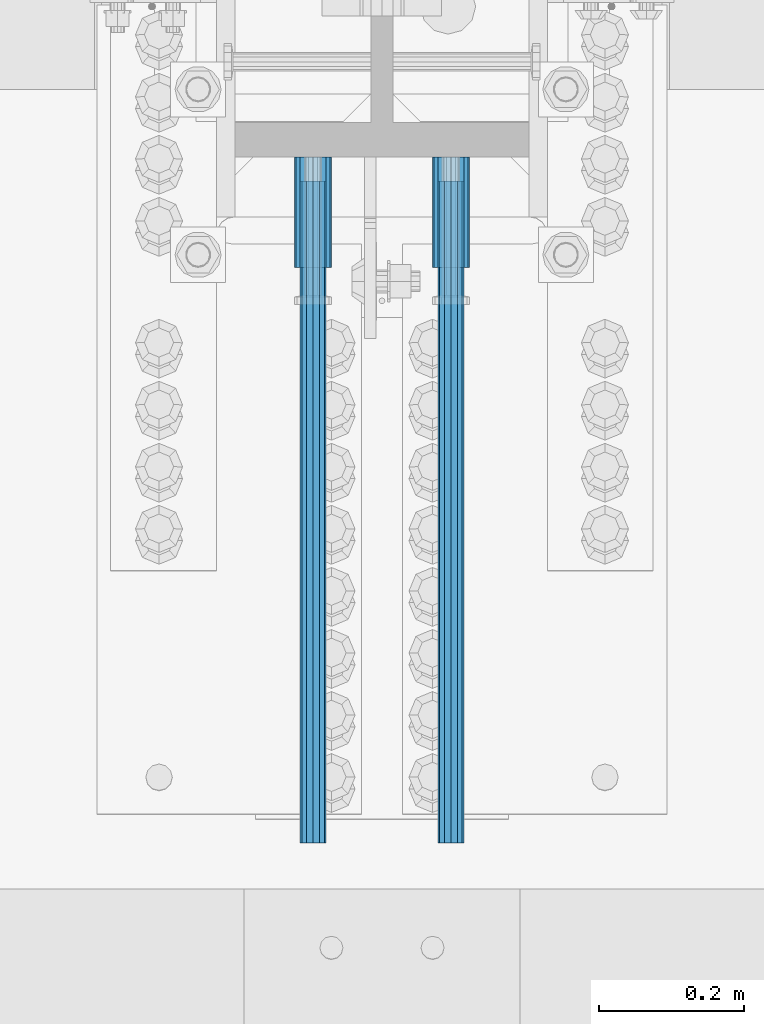
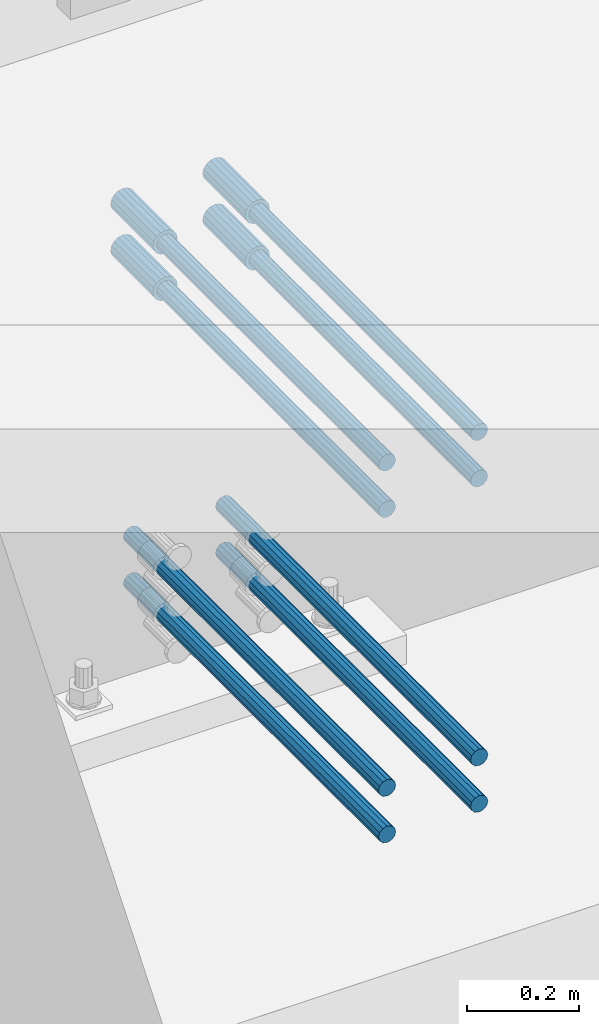
# One storey, part 1314 of 1763: 12 beams, 9 elements without a shape of their own.
"""IFC2X3 building model written with IfcOpenShell, lengths in millimetres."""

from ifc_helpers import new_model, si_unit, frame, origin_with_axes, place, context, subcontext, project, spatial, faceted_brep, material, type_object, element, aggregate, save


model = new_model("IFC2X3")

# Units and contexts
model_context = context("Model", 3, precision=1e-05, world=origin_with_axes())
body_context = subcontext(model_context, "Body", "Model", "MODEL_VIEW")
ifc_project = project(units=[si_unit("LENGTHUNIT", "METRE", prefix="MILLI"), si_unit("AREAUNIT", "SQUARE_METRE"), si_unit("VOLUMEUNIT", "CUBIC_METRE"), si_unit("MASSUNIT", "GRAM", prefix="KILO"), si_unit("TIMEUNIT", "SECOND"), si_unit("PLANEANGLEUNIT", "RADIAN"), si_unit("SOLIDANGLEUNIT", "STERADIAN"), si_unit("THERMODYNAMICTEMPERATUREUNIT", "DEGREE_CELSIUS"), si_unit("LUMINOUSINTENSITYUNIT", "LUMEN")], contexts=[model_context])

# Site, building, storey
site_placement = place(None, origin_with_axes())
site = spatial("IfcSite", under=ifc_project, at=site_placement, CompositionType="ELEMENT")
building_placement = place(site_placement, origin_with_axes())
building = spatial("IfcBuilding", under=site, at=building_placement, Name="Undefined", CompositionType="ELEMENT")
storey_placement = place(building_placement, origin_with_axes())
storey = spatial("IfcBuildingStorey", under=building, at=storey_placement, Name="Undefined", CompositionType="ELEMENT", Elevation=0.0)

# Assembly, beams
assembly_1_placement = place(storey_placement, origin_with_axes())
assembly_1 = element("IfcElementAssembly", 1, at=assembly_1_placement, inside=storey, Name="COLUMN", AssemblyPlace="NOTDEFINED", PredefinedType="RIGID_FRAME")
ifc_material = material(Name="STEEL/A706-GR.80")
beam_type_1 = type_object("IfcBeamType", PredefinedType="NOTDEFINED")
beam_1_placement = place(assembly_1_placement, frame((-24123.0872736984, 13482.6375920513, 4775.20000000009), z_axis=(0.0, 0.0, 1.0), x_axis=(0.0, -1.0, 0.0)))
beam_1 = element("IfcBeam", 2, at=beam_1_placement, type_object=beam_type_1, material=ifc_material, Name="HALF COUPLER F", context=body_context, shape_type="Brep", body=[
    faceted_brep([(32.7659999999996, -8.95349999999962, -15.507916905568), (32.7659999999996, 0.0, -17.9070000000002), (32.7659999999996, 8.95349999999962, -15.507916905568), (32.7659999999996, 15.507916905568, -8.95350000000008), (32.7659999999996, 17.9069999999992, 0.0), (32.7659999999996, 15.507916905568, 8.95350000000008), (32.7659999999996, 8.95349999999962, 15.507916905568), (32.7659999999996, 0.0, 17.9070000000002), (32.7659999999996, -8.95349999999962, 15.507916905568), (32.7659999999996, -15.507916905568, 8.95350000000008), (32.7659999999996, -17.9069999999992, 0.0), (32.7659999999996, -15.507916905568, -8.95350000000008), (152.400103102711, -15.507916905568, 8.95350000000008), (152.400103102711, -8.95349999999962, 15.507916905568), (152.400103102711, -17.9069999999992, 0.0), (152.400103102711, -15.507916905568, -8.95350000000008), (152.400103102711, -8.95349999999962, -15.507916905568), (152.400103102711, 0.0, -17.9070000000002), (152.400103102711, 8.95349999999962, -15.507916905568), (152.400103102711, 15.507916905568, -8.95350000000008), (152.400103102711, 17.9069999999992, 0.0), (152.400103102711, 15.507916905568, 8.95350000000008), (152.400103102711, 8.95349999999962, 15.507916905568), (152.400103102711, 0.0, 17.9070000000002), (0.0, -23.466540125788, 9.72015918207308), (0.0, -17.9605122421381, 17.9605122421385), (0.0, -9.72015918207398, 23.4665401257867), (0.0, 0.0, 25.4000000000001), (0.0, 9.72015918207398, 23.4665401257867), (0.0, 17.9605122421381, 17.9605122421385), (0.0, 23.466540125788, 9.72015918207308), (0.0, 25.4000000000015, 0.0), (0.0, 23.466540125788, -9.72015918207308), (0.0, 17.9605122421381, -17.9605122421385), (0.0, 9.72015918207398, -23.4665401257867), (0.0, 0.0, -25.4000000000001), (0.0, -9.72015918207398, -23.4665401257867), (0.0, -17.9605122421381, -17.9605122421385), (0.0, -23.466540125788, -9.72015918207308), (0.0, -25.4000000000015, 0.0), (152.400103102711, -25.4000000000015, 0.0), (152.400103102711, -23.466540125788, 9.72015918207308), (152.400103102711, -17.9605122421381, 17.9605122421385), (152.400103102711, -9.72015918207398, 23.4665401257867), (152.400103102711, 0.0, 25.4000000000001), (152.400103102711, 9.72015918207398, 23.4665401257867), (152.400103102711, 17.9605122421381, 17.9605122421385), (152.400103102711, 23.466540125788, 9.72015918207308), (152.400103102711, 25.4000000000015, 0.0), (152.400103102711, 23.466540125788, -9.72015918207308), (152.400103102711, 17.9605122421381, -17.9605122421385), (152.400103102711, 9.72015918207398, -23.4665401257867), (152.400103102711, 0.0, -25.4000000000001), (152.400103102711, -9.72015918207398, -23.4665401257867), (152.400103102711, -17.9605122421381, -17.9605122421385), (152.400103102711, -23.466540125788, -9.72015918207308)], [[[0, 1, 2, 3, 4, 5, 6, 7, 8, 9, 10, 11]], [[12, 9, 8, 13]], [[14, 10, 9, 12]], [[15, 11, 10, 14]], [[16, 0, 11, 15]], [[17, 1, 0, 16]], [[18, 2, 1, 17]], [[19, 3, 2, 18]], [[20, 4, 3, 19]], [[21, 5, 4, 20]], [[22, 6, 5, 21]], [[23, 7, 6, 22]], [[13, 8, 7, 23]], [[24, 25, 26, 27, 28, 29, 30, 31, 32, 33, 34, 35, 36, 37, 38, 39]], [[24, 39, 40, 41]], [[25, 24, 41, 42]], [[26, 25, 42, 43]], [[27, 26, 43, 44]], [[28, 27, 44, 45]], [[29, 28, 45, 46]], [[30, 29, 46, 47]], [[31, 30, 47, 48]], [[32, 31, 48, 49]], [[33, 32, 49, 50]], [[34, 33, 50, 51]], [[35, 34, 51, 52]], [[36, 35, 52, 53]], [[37, 36, 53, 54]], [[38, 37, 54, 55]], [[39, 38, 55, 40]], [[54, 53, 52, 51, 50, 49, 48, 47, 46, 45, 44, 43, 42, 41, 40, 55], [21, 20, 19, 18, 17, 16, 15, 14, 12, 13, 23, 22]]]),
])
beam_2_placement = place(assembly_1_placement, frame((-23932.5872736985, 13482.6376607869, 4775.20000000009), z_axis=(0.0, 0.0, 1.0), x_axis=(0.0, -1.0, 0.0)))
beam_2 = element("IfcBeam", 3, at=beam_2_placement, type_object=beam_type_1, material=ifc_material, Name="HALF COUPLER F", context=body_context, shape_type="Brep", body=[
    faceted_brep([(32.7659999999996, -8.95349999999962, -15.507916905568), (32.7659999999996, 0.0, -17.9070000000002), (32.7659999999996, 8.95349999999962, -15.507916905568), (32.7659999999996, 15.507916905568, -8.95350000000008), (32.7659999999996, 17.9069999999992, 0.0), (32.7659999999996, 15.507916905568, 8.95350000000008), (32.7659999999996, 8.95349999999962, 15.507916905568), (32.7659999999996, 0.0, 17.9070000000002), (32.7659999999996, -8.95349999999962, 15.507916905568), (32.7659999999996, -15.507916905568, 8.95350000000008), (32.7659999999996, -17.9069999999992, 0.0), (32.7659999999996, -15.507916905568, -8.95350000000008), (152.400103102711, -15.507916905568, 8.95350000000008), (152.400103102711, -8.95349999999962, 15.507916905568), (152.400103102711, -17.9069999999992, 0.0), (152.400103102711, -15.507916905568, -8.95350000000008), (152.400103102711, -8.95349999999962, -15.507916905568), (152.400103102711, 0.0, -17.9070000000002), (152.400103102711, 8.95349999999962, -15.507916905568), (152.400103102711, 15.507916905568, -8.95350000000008), (152.400103102711, 17.9069999999992, 0.0), (152.400103102711, 15.507916905568, 8.95350000000008), (152.400103102711, 8.95349999999962, 15.507916905568), (152.400103102711, 0.0, 17.9070000000002), (0.0, -23.466540125788, 9.72015918207308), (0.0, -17.9605122421381, 17.9605122421385), (0.0, -9.72015918207398, 23.4665401257867), (0.0, 0.0, 25.4000000000001), (0.0, 9.72015918207398, 23.4665401257867), (0.0, 17.9605122421381, 17.9605122421385), (0.0, 23.466540125788, 9.72015918207308), (0.0, 25.4000000000015, 0.0), (0.0, 23.466540125788, -9.72015918207308), (0.0, 17.9605122421381, -17.9605122421385), (0.0, 9.72015918207398, -23.4665401257867), (0.0, 0.0, -25.4000000000001), (0.0, -9.72015918207398, -23.4665401257867), (0.0, -17.9605122421381, -17.9605122421385), (0.0, -23.466540125788, -9.72015918207308), (0.0, -25.4000000000015, 0.0), (152.400103102711, -25.4000000000015, 0.0), (152.400103102711, -23.466540125788, 9.72015918207308), (152.400103102711, -17.9605122421381, 17.9605122421385), (152.400103102711, -9.72015918207398, 23.4665401257867), (152.400103102711, 0.0, 25.4000000000001), (152.400103102711, 9.72015918207398, 23.4665401257867), (152.400103102711, 17.9605122421381, 17.9605122421385), (152.400103102711, 23.466540125788, 9.72015918207308), (152.400103102711, 25.4000000000015, 0.0), (152.400103102711, 23.466540125788, -9.72015918207308), (152.400103102711, 17.9605122421381, -17.9605122421385), (152.400103102711, 9.72015918207398, -23.4665401257867), (152.400103102711, 0.0, -25.4000000000001), (152.400103102711, -9.72015918207398, -23.4665401257867), (152.400103102711, -17.9605122421381, -17.9605122421385), (152.400103102711, -23.466540125788, -9.72015918207308)], [[[0, 1, 2, 3, 4, 5, 6, 7, 8, 9, 10, 11]], [[12, 9, 8, 13]], [[14, 10, 9, 12]], [[15, 11, 10, 14]], [[16, 0, 11, 15]], [[17, 1, 0, 16]], [[18, 2, 1, 17]], [[19, 3, 2, 18]], [[20, 4, 3, 19]], [[21, 5, 4, 20]], [[22, 6, 5, 21]], [[23, 7, 6, 22]], [[13, 8, 7, 23]], [[24, 25, 26, 27, 28, 29, 30, 31, 32, 33, 34, 35, 36, 37, 38, 39]], [[24, 39, 40, 41]], [[25, 24, 41, 42]], [[26, 25, 42, 43]], [[27, 26, 43, 44]], [[28, 27, 44, 45]], [[29, 28, 45, 46]], [[30, 29, 46, 47]], [[31, 30, 47, 48]], [[32, 31, 48, 49]], [[33, 32, 49, 50]], [[34, 33, 50, 51]], [[35, 34, 51, 52]], [[36, 35, 52, 53]], [[37, 36, 53, 54]], [[38, 37, 54, 55]], [[39, 38, 55, 40]], [[54, 53, 52, 51, 50, 49, 48, 47, 46, 45, 44, 43, 42, 41, 40, 55], [21, 20, 19, 18, 17, 16, 15, 14, 12, 13, 23, 22]]]),
])
beam_3_placement = place(assembly_1_placement, frame((-24123.0872736984, 13482.6374545803, 4876.80000000009), z_axis=(0.0, 0.0, 1.0), x_axis=(0.0, -1.0, 0.0)))
beam_3 = element("IfcBeam", 4, at=beam_3_placement, type_object=beam_type_1, material=ifc_material, Name="HALF COUPLER F", context=body_context, shape_type="Brep", body=[
    faceted_brep([(32.7659999999996, -8.95349999999962, -15.507916905568), (32.7659999999996, 0.0, -17.9070000000002), (32.7659999999996, 8.95349999999962, -15.507916905568), (32.7659999999996, 15.507916905568, -8.95350000000008), (32.7659999999996, 17.9069999999992, 0.0), (32.7659999999996, 15.507916905568, 8.95350000000008), (32.7659999999996, 8.95349999999962, 15.507916905568), (32.7659999999996, 0.0, 17.9070000000002), (32.7659999999996, -8.95349999999962, 15.507916905568), (32.7659999999996, -15.507916905568, 8.95350000000008), (32.7659999999996, -17.9069999999992, 0.0), (32.7659999999996, -15.507916905568, -8.95350000000008), (152.400103102711, -15.507916905568, 8.95350000000008), (152.400103102711, -8.95349999999962, 15.507916905568), (152.400103102711, -17.9069999999992, 0.0), (152.400103102711, -15.507916905568, -8.95350000000008), (152.400103102711, -8.95349999999962, -15.507916905568), (152.400103102711, 0.0, -17.9070000000002), (152.400103102711, 8.95349999999962, -15.507916905568), (152.400103102711, 15.507916905568, -8.95350000000008), (152.400103102711, 17.9069999999992, 0.0), (152.400103102711, 15.507916905568, 8.95350000000008), (152.400103102711, 8.95349999999962, 15.507916905568), (152.400103102711, 0.0, 17.9070000000002), (0.0, -23.466540125788, 9.72015918207308), (0.0, -17.9605122421381, 17.9605122421385), (0.0, -9.72015918207398, 23.4665401257867), (0.0, 0.0, 25.4000000000001), (0.0, 9.72015918207398, 23.4665401257867), (0.0, 17.9605122421381, 17.9605122421385), (0.0, 23.466540125788, 9.72015918207308), (0.0, 25.4000000000015, 0.0), (0.0, 23.466540125788, -9.72015918207308), (0.0, 17.9605122421381, -17.9605122421385), (0.0, 9.72015918207398, -23.4665401257867), (0.0, 0.0, -25.4000000000001), (0.0, -9.72015918207398, -23.4665401257867), (0.0, -17.9605122421381, -17.9605122421385), (0.0, -23.466540125788, -9.72015918207308), (0.0, -25.4000000000015, 0.0), (152.400103102711, -25.4000000000015, 0.0), (152.400103102711, -23.466540125788, 9.72015918207308), (152.400103102711, -17.9605122421381, 17.9605122421385), (152.400103102711, -9.72015918207398, 23.4665401257867), (152.400103102711, 0.0, 25.4000000000001), (152.400103102711, 9.72015918207398, 23.4665401257867), (152.400103102711, 17.9605122421381, 17.9605122421385), (152.400103102711, 23.466540125788, 9.72015918207308), (152.400103102711, 25.4000000000015, 0.0), (152.400103102711, 23.466540125788, -9.72015918207308), (152.400103102711, 17.9605122421381, -17.9605122421385), (152.400103102711, 9.72015918207398, -23.4665401257867), (152.400103102711, 0.0, -25.4000000000001), (152.400103102711, -9.72015918207398, -23.4665401257867), (152.400103102711, -17.9605122421381, -17.9605122421385), (152.400103102711, -23.466540125788, -9.72015918207308)], [[[0, 1, 2, 3, 4, 5, 6, 7, 8, 9, 10, 11]], [[12, 9, 8, 13]], [[14, 10, 9, 12]], [[15, 11, 10, 14]], [[16, 0, 11, 15]], [[17, 1, 0, 16]], [[18, 2, 1, 17]], [[19, 3, 2, 18]], [[20, 4, 3, 19]], [[21, 5, 4, 20]], [[22, 6, 5, 21]], [[23, 7, 6, 22]], [[13, 8, 7, 23]], [[24, 25, 26, 27, 28, 29, 30, 31, 32, 33, 34, 35, 36, 37, 38, 39]], [[24, 39, 40, 41]], [[25, 24, 41, 42]], [[26, 25, 42, 43]], [[27, 26, 43, 44]], [[28, 27, 44, 45]], [[29, 28, 45, 46]], [[30, 29, 46, 47]], [[31, 30, 47, 48]], [[32, 31, 48, 49]], [[33, 32, 49, 50]], [[34, 33, 50, 51]], [[35, 34, 51, 52]], [[36, 35, 52, 53]], [[37, 36, 53, 54]], [[38, 37, 54, 55]], [[39, 38, 55, 40]], [[54, 53, 52, 51, 50, 49, 48, 47, 46, 45, 44, 43, 42, 41, 40, 55], [21, 20, 19, 18, 17, 16, 15, 14, 12, 13, 23, 22]]]),
])
beam_4_placement = place(assembly_1_placement, frame((-23932.5872736985, 13482.6375233158, 4876.80000000009), z_axis=(0.0, 0.0, 1.0), x_axis=(0.0, -1.0, 0.0)))
beam_4 = element("IfcBeam", 5, at=beam_4_placement, type_object=beam_type_1, material=ifc_material, Name="HALF COUPLER F", context=body_context, shape_type="Brep", body=[
    faceted_brep([(32.7659999999996, -8.95349999999962, -15.507916905568), (32.7659999999996, 0.0, -17.9070000000002), (32.7659999999996, 8.95349999999962, -15.507916905568), (32.7659999999996, 15.507916905568, -8.95350000000008), (32.7659999999996, 17.9069999999992, 0.0), (32.7659999999996, 15.507916905568, 8.95350000000008), (32.7659999999996, 8.95349999999962, 15.507916905568), (32.7659999999996, 0.0, 17.9070000000002), (32.7659999999996, -8.95349999999962, 15.507916905568), (32.7659999999996, -15.507916905568, 8.95350000000008), (32.7659999999996, -17.9069999999992, 0.0), (32.7659999999996, -15.507916905568, -8.95350000000008), (152.400103102711, -15.507916905568, 8.95350000000008), (152.400103102711, -8.95349999999962, 15.507916905568), (152.400103102711, -17.9069999999992, 0.0), (152.400103102711, -15.507916905568, -8.95350000000008), (152.400103102711, -8.95349999999962, -15.507916905568), (152.400103102711, 0.0, -17.9070000000002), (152.400103102711, 8.95349999999962, -15.507916905568), (152.400103102711, 15.507916905568, -8.95350000000008), (152.400103102711, 17.9069999999992, 0.0), (152.400103102711, 15.507916905568, 8.95350000000008), (152.400103102711, 8.95349999999962, 15.507916905568), (152.400103102711, 0.0, 17.9070000000002), (0.0, -23.466540125788, 9.72015918207308), (0.0, -17.9605122421381, 17.9605122421385), (0.0, -9.72015918207398, 23.4665401257867), (0.0, 0.0, 25.4000000000001), (0.0, 9.72015918207398, 23.4665401257867), (0.0, 17.9605122421381, 17.9605122421385), (0.0, 23.466540125788, 9.72015918207308), (0.0, 25.4000000000015, 0.0), (0.0, 23.466540125788, -9.72015918207308), (0.0, 17.9605122421381, -17.9605122421385), (0.0, 9.72015918207398, -23.4665401257867), (0.0, 0.0, -25.4000000000001), (0.0, -9.72015918207398, -23.4665401257867), (0.0, -17.9605122421381, -17.9605122421385), (0.0, -23.466540125788, -9.72015918207308), (0.0, -25.4000000000015, 0.0), (152.400103102711, -25.4000000000015, 0.0), (152.400103102711, -23.466540125788, 9.72015918207308), (152.400103102711, -17.9605122421381, 17.9605122421385), (152.400103102711, -9.72015918207398, 23.4665401257867), (152.400103102711, 0.0, 25.4000000000001), (152.400103102711, 9.72015918207398, 23.4665401257867), (152.400103102711, 17.9605122421381, 17.9605122421385), (152.400103102711, 23.466540125788, 9.72015918207308), (152.400103102711, 25.4000000000015, 0.0), (152.400103102711, 23.466540125788, -9.72015918207308), (152.400103102711, 17.9605122421381, -17.9605122421385), (152.400103102711, 9.72015918207398, -23.4665401257867), (152.400103102711, 0.0, -25.4000000000001), (152.400103102711, -9.72015918207398, -23.4665401257867), (152.400103102711, -17.9605122421381, -17.9605122421385), (152.400103102711, -23.466540125788, -9.72015918207308)], [[[0, 1, 2, 3, 4, 5, 6, 7, 8, 9, 10, 11]], [[12, 9, 8, 13]], [[14, 10, 9, 12]], [[15, 11, 10, 14]], [[16, 0, 11, 15]], [[17, 1, 0, 16]], [[18, 2, 1, 17]], [[19, 3, 2, 18]], [[20, 4, 3, 19]], [[21, 5, 4, 20]], [[22, 6, 5, 21]], [[23, 7, 6, 22]], [[13, 8, 7, 23]], [[24, 25, 26, 27, 28, 29, 30, 31, 32, 33, 34, 35, 36, 37, 38, 39]], [[24, 39, 40, 41]], [[25, 24, 41, 42]], [[26, 25, 42, 43]], [[27, 26, 43, 44]], [[28, 27, 44, 45]], [[29, 28, 45, 46]], [[30, 29, 46, 47]], [[31, 30, 47, 48]], [[32, 31, 48, 49]], [[33, 32, 49, 50]], [[34, 33, 50, 51]], [[35, 34, 51, 52]], [[36, 35, 52, 53]], [[37, 36, 53, 54]], [[38, 37, 54, 55]], [[39, 38, 55, 40]], [[54, 53, 52, 51, 50, 49, 48, 47, 46, 45, 44, 43, 42, 41, 40, 55], [21, 20, 19, 18, 17, 16, 15, 14, 12, 13, 23, 22]]]),
])
aggregate(assembly_1, [beam_1, beam_2, beam_3, beam_4])

# Assembly, beam
assembly_2_placement = place(storey_placement, origin_with_axes())
assembly_2 = element("IfcElementAssembly", 6, at=assembly_2_placement, inside=storey, Name="REBAR", AssemblyPlace="NOTDEFINED", PredefinedType="RIGID_FRAME")
beam_type_2 = type_object("IfcBeamType", Name="#11 REBAR", PredefinedType="NOTDEFINED")
beam_5_placement = place(assembly_2_placement, frame((-24123.0872736978, 13449.8717982573, 4165.6), z_axis=(0.0, 0.0, 1.0), x_axis=(0.0, -1.0, 0.0)))
beam_5 = element("IfcBeam", 7, at=beam_5_placement, type_object=beam_type_2, material=ifc_material, Name="REBAR", ObjectType="#11 REBAR", context=body_context, shape_type="Brep", body=[
    faceted_brep([(0.0, -17.9069999999992, 0.0), (0.0, -15.507916905568, -8.95349999999962), (914.400000001086, -15.507916905568, -8.95349999999962), (914.400000001086, -17.9069999999992, 0.0), (0.0, -8.95349999999962, -15.507916905568), (914.400000001086, -8.95349999999962, -15.507916905568), (0.0, 0.0, -17.9070000000002), (914.400000001086, 0.0, -17.9070000000002), (0.0, 8.95349999999962, -15.507916905568), (914.400000001086, 8.95349999999962, -15.507916905568), (0.0, 15.507916905568, -8.95349999999962), (914.400000001086, 15.507916905568, -8.95349999999962), (0.0, 17.9069999999992, 0.0), (914.400000001086, 17.9069999999992, 0.0), (0.0, 15.507916905568, 8.95349999999962), (914.400000001086, 15.507916905568, 8.95349999999962), (0.0, 8.95349999999962, 15.507916905568), (914.400000001086, 8.95349999999962, 15.507916905568), (0.0, 0.0, 17.9070000000002), (914.400000001086, 0.0, 17.9070000000002), (0.0, -8.95349999999962, 15.507916905568), (914.400000001086, -8.95349999999962, 15.507916905568), (0.0, -15.507916905568, 8.95349999999962), (914.400000001086, -15.507916905568, 8.95349999999962)], [[[0, 1, 2, 3]], [[1, 4, 5, 2]], [[4, 6, 7, 5]], [[6, 8, 9, 7]], [[8, 10, 11, 9]], [[10, 12, 13, 11]], [[12, 14, 15, 13]], [[14, 16, 17, 15]], [[16, 18, 19, 17]], [[18, 20, 21, 19]], [[20, 22, 23, 21]], [[22, 0, 3, 23]], [[5, 7, 9, 11, 13, 15, 17, 19, 21, 23, 3, 2]], [[22, 20, 18, 16, 14, 12, 10, 8, 6, 4, 1, 0]]]),
])
aggregate(assembly_2, [beam_5])

assembly_3_placement = place(storey_placement, origin_with_axes())
assembly_3 = element("IfcElementAssembly", 8, at=assembly_3_placement, inside=storey, Name="REBAR", AssemblyPlace="NOTDEFINED", PredefinedType="RIGID_FRAME")
beam_6_placement = place(assembly_3_placement, frame((-23932.5872736984, 13449.8717295968, 4165.6), z_axis=(0.0, 0.0, 1.0), x_axis=(0.0, -1.0, 0.0)))
beam_6 = element("IfcBeam", 9, at=beam_6_placement, type_object=beam_type_2, material=ifc_material, Name="REBAR", ObjectType="#11 REBAR", context=body_context, shape_type="Brep", body=[
    faceted_brep([(0.0, -17.9069999999992, 0.0), (0.0, -15.507916905568, -8.95349999999962), (914.400000001086, -15.507916905568, -8.95349999999962), (914.400000001086, -17.9069999999992, 0.0), (0.0, -8.95349999999962, -15.507916905568), (914.400000001086, -8.95349999999962, -15.507916905568), (0.0, 0.0, -17.9070000000002), (914.400000001086, 0.0, -17.9070000000002), (0.0, 8.95349999999962, -15.507916905568), (914.400000001086, 8.95349999999962, -15.507916905568), (0.0, 15.507916905568, -8.95349999999962), (914.400000001086, 15.507916905568, -8.95349999999962), (0.0, 17.9069999999992, 0.0), (914.400000001086, 17.9069999999992, 0.0), (0.0, 15.507916905568, 8.95349999999962), (914.400000001086, 15.507916905568, 8.95349999999962), (0.0, 8.95349999999962, 15.507916905568), (914.400000001086, 8.95349999999962, 15.507916905568), (0.0, 0.0, 17.9070000000002), (914.400000001086, 0.0, 17.9070000000002), (0.0, -8.95349999999962, 15.507916905568), (914.400000001086, -8.95349999999962, 15.507916905568), (0.0, -15.507916905568, 8.95349999999962), (914.400000001086, -15.507916905568, 8.95349999999962)], [[[0, 1, 2, 3]], [[1, 4, 5, 2]], [[4, 6, 7, 5]], [[6, 8, 9, 7]], [[8, 10, 11, 9]], [[10, 12, 13, 11]], [[12, 14, 15, 13]], [[14, 16, 17, 15]], [[16, 18, 19, 17]], [[18, 20, 21, 19]], [[20, 22, 23, 21]], [[22, 0, 3, 23]], [[5, 7, 9, 11, 13, 15, 17, 19, 21, 23, 3, 2]], [[22, 20, 18, 16, 14, 12, 10, 8, 6, 4, 1, 0]]]),
])
aggregate(assembly_3, [beam_6])

assembly_4_placement = place(storey_placement, origin_with_axes())
assembly_4 = element("IfcElementAssembly", 10, at=assembly_4_placement, inside=storey, Name="REBAR", AssemblyPlace="NOTDEFINED", PredefinedType="RIGID_FRAME")
beam_7_placement = place(assembly_4_placement, frame((-24123.0872736978, 13449.8717982573, 4064.0), z_axis=(0.0, 0.0, 1.0), x_axis=(0.0, -1.0, 0.0)))
beam_7 = element("IfcBeam", 11, at=beam_7_placement, type_object=beam_type_2, material=ifc_material, Name="REBAR", ObjectType="#11 REBAR", context=body_context, shape_type="Brep", body=[
    faceted_brep([(0.0, -17.9069999999992, 0.0), (0.0, -15.507916905568, -8.95349999999962), (914.400000001086, -15.507916905568, -8.95349999999962), (914.400000001086, -17.9069999999992, 0.0), (0.0, -8.95349999999962, -15.507916905568), (914.400000001086, -8.95349999999962, -15.507916905568), (0.0, 0.0, -17.9070000000002), (914.400000001086, 0.0, -17.9070000000002), (0.0, 8.95349999999962, -15.507916905568), (914.400000001086, 8.95349999999962, -15.507916905568), (0.0, 15.507916905568, -8.95349999999962), (914.400000001086, 15.507916905568, -8.95349999999962), (0.0, 17.9069999999992, 0.0), (914.400000001086, 17.9069999999992, 0.0), (0.0, 15.507916905568, 8.95349999999962), (914.400000001086, 15.507916905568, 8.95349999999962), (0.0, 8.95349999999962, 15.507916905568), (914.400000001086, 8.95349999999962, 15.507916905568), (0.0, 0.0, 17.9070000000002), (914.400000001086, 0.0, 17.9070000000002), (0.0, -8.95349999999962, 15.507916905568), (914.400000001086, -8.95349999999962, 15.507916905568), (0.0, -15.507916905568, 8.95349999999962), (914.400000001086, -15.507916905568, 8.95349999999962)], [[[0, 1, 2, 3]], [[1, 4, 5, 2]], [[4, 6, 7, 5]], [[6, 8, 9, 7]], [[8, 10, 11, 9]], [[10, 12, 13, 11]], [[12, 14, 15, 13]], [[14, 16, 17, 15]], [[16, 18, 19, 17]], [[18, 20, 21, 19]], [[20, 22, 23, 21]], [[22, 0, 3, 23]], [[5, 7, 9, 11, 13, 15, 17, 19, 21, 23, 3, 2]], [[22, 20, 18, 16, 14, 12, 10, 8, 6, 4, 1, 0]]]),
])
aggregate(assembly_4, [beam_7])

assembly_5_placement = place(storey_placement, origin_with_axes())
assembly_5 = element("IfcElementAssembly", 12, at=assembly_5_placement, inside=storey, Name="REBAR", AssemblyPlace="NOTDEFINED", PredefinedType="RIGID_FRAME")
beam_8_placement = place(assembly_5_placement, frame((-23932.5872736984, 13449.8717295968, 4064.0), z_axis=(0.0, 0.0, 1.0), x_axis=(0.0, -1.0, 0.0)))
beam_8 = element("IfcBeam", 13, at=beam_8_placement, type_object=beam_type_2, material=ifc_material, Name="REBAR", ObjectType="#11 REBAR", context=body_context, shape_type="Brep", body=[
    faceted_brep([(0.0, -17.9069999999992, 0.0), (0.0, -15.507916905568, -8.95349999999962), (914.400000001086, -15.507916905568, -8.95349999999962), (914.400000001086, -17.9069999999992, 0.0), (0.0, -8.95349999999962, -15.507916905568), (914.400000001086, -8.95349999999962, -15.507916905568), (0.0, 0.0, -17.9070000000002), (914.400000001086, 0.0, -17.9070000000002), (0.0, 8.95349999999962, -15.507916905568), (914.400000001086, 8.95349999999962, -15.507916905568), (0.0, 15.507916905568, -8.95349999999962), (914.400000001086, 15.507916905568, -8.95349999999962), (0.0, 17.9069999999992, 0.0), (914.400000001086, 17.9069999999992, 0.0), (0.0, 15.507916905568, 8.95349999999962), (914.400000001086, 15.507916905568, 8.95349999999962), (0.0, 8.95349999999962, 15.507916905568), (914.400000001086, 8.95349999999962, 15.507916905568), (0.0, 0.0, 17.9070000000002), (914.400000001086, 0.0, 17.9070000000002), (0.0, -8.95349999999962, 15.507916905568), (914.400000001086, -8.95349999999962, 15.507916905568), (0.0, -15.507916905568, 8.95349999999962), (914.400000001086, -15.507916905568, 8.95349999999962)], [[[0, 1, 2, 3]], [[1, 4, 5, 2]], [[4, 6, 7, 5]], [[6, 8, 9, 7]], [[8, 10, 11, 9]], [[10, 12, 13, 11]], [[12, 14, 15, 13]], [[14, 16, 17, 15]], [[16, 18, 19, 17]], [[18, 20, 21, 19]], [[20, 22, 23, 21]], [[22, 0, 3, 23]], [[5, 7, 9, 11, 13, 15, 17, 19, 21, 23, 3, 2]], [[22, 20, 18, 16, 14, 12, 10, 8, 6, 4, 1, 0]]]),
])
aggregate(assembly_5, [beam_8])

assembly_6_placement = place(storey_placement, origin_with_axes())
assembly_6 = element("IfcElementAssembly", 14, at=assembly_6_placement, inside=storey, Name="REBAR", AssemblyPlace="NOTDEFINED", PredefinedType="RIGID_FRAME")
beam_9_placement = place(assembly_6_placement, frame((-24123.0872736978, 13449.8717982573, 4876.8), z_axis=(0.0, 0.0, 1.0), x_axis=(0.0, -1.0, 0.0)))
beam_9 = element("IfcBeam", 15, at=beam_9_placement, type_object=beam_type_2, material=ifc_material, Name="REBAR", ObjectType="#11 REBAR", context=body_context, shape_type="Brep", body=[
    faceted_brep([(0.0, -17.9069999999992, 0.0), (0.0, -15.507916905568, -8.95349999999962), (914.400000001086, -15.507916905568, -8.95349999999962), (914.400000001086, -17.9069999999992, 0.0), (0.0, -8.95349999999962, -15.507916905568), (914.400000001086, -8.95349999999962, -15.507916905568), (0.0, 0.0, -17.9070000000002), (914.400000001086, 0.0, -17.9070000000002), (0.0, 8.95349999999962, -15.507916905568), (914.400000001086, 8.95349999999962, -15.507916905568), (0.0, 15.507916905568, -8.95349999999962), (914.400000001086, 15.507916905568, -8.95349999999962), (0.0, 17.9069999999992, 0.0), (914.400000001086, 17.9069999999992, 0.0), (0.0, 15.507916905568, 8.95349999999962), (914.400000001086, 15.507916905568, 8.95349999999962), (0.0, 8.95349999999962, 15.507916905568), (914.400000001086, 8.95349999999962, 15.507916905568), (0.0, 0.0, 17.9070000000002), (914.400000001086, 0.0, 17.9070000000002), (0.0, -8.95349999999962, 15.507916905568), (914.400000001086, -8.95349999999962, 15.507916905568), (0.0, -15.507916905568, 8.95349999999962), (914.400000001086, -15.507916905568, 8.95349999999962)], [[[0, 1, 2, 3]], [[1, 4, 5, 2]], [[4, 6, 7, 5]], [[6, 8, 9, 7]], [[8, 10, 11, 9]], [[10, 12, 13, 11]], [[12, 14, 15, 13]], [[14, 16, 17, 15]], [[16, 18, 19, 17]], [[18, 20, 21, 19]], [[20, 22, 23, 21]], [[22, 0, 3, 23]], [[5, 7, 9, 11, 13, 15, 17, 19, 21, 23, 3, 2]], [[22, 20, 18, 16, 14, 12, 10, 8, 6, 4, 1, 0]]]),
])
aggregate(assembly_6, [beam_9])

assembly_7_placement = place(storey_placement, origin_with_axes())
assembly_7 = element("IfcElementAssembly", 16, at=assembly_7_placement, inside=storey, Name="REBAR", AssemblyPlace="NOTDEFINED", PredefinedType="RIGID_FRAME")
beam_10_placement = place(assembly_7_placement, frame((-23932.5872736984, 13449.8717295968, 4876.8), z_axis=(0.0, 0.0, 1.0), x_axis=(0.0, -1.0, 0.0)))
beam_10 = element("IfcBeam", 17, at=beam_10_placement, type_object=beam_type_2, material=ifc_material, Name="REBAR", ObjectType="#11 REBAR", context=body_context, shape_type="Brep", body=[
    faceted_brep([(0.0, -17.9069999999992, 0.0), (0.0, -15.507916905568, -8.95349999999962), (914.400000001086, -15.507916905568, -8.95349999999962), (914.400000001086, -17.9069999999992, 0.0), (0.0, -8.95349999999962, -15.507916905568), (914.400000001086, -8.95349999999962, -15.507916905568), (0.0, 0.0, -17.9070000000002), (914.400000001086, 0.0, -17.9070000000002), (0.0, 8.95349999999962, -15.507916905568), (914.400000001086, 8.95349999999962, -15.507916905568), (0.0, 15.507916905568, -8.95349999999962), (914.400000001086, 15.507916905568, -8.95349999999962), (0.0, 17.9069999999992, 0.0), (914.400000001086, 17.9069999999992, 0.0), (0.0, 15.507916905568, 8.95349999999962), (914.400000001086, 15.507916905568, 8.95349999999962), (0.0, 8.95349999999962, 15.507916905568), (914.400000001086, 8.95349999999962, 15.507916905568), (0.0, 0.0, 17.9070000000002), (914.400000001086, 0.0, 17.9070000000002), (0.0, -8.95349999999962, 15.507916905568), (914.400000001086, -8.95349999999962, 15.507916905568), (0.0, -15.507916905568, 8.95349999999962), (914.400000001086, -15.507916905568, 8.95349999999962)], [[[0, 1, 2, 3]], [[1, 4, 5, 2]], [[4, 6, 7, 5]], [[6, 8, 9, 7]], [[8, 10, 11, 9]], [[10, 12, 13, 11]], [[12, 14, 15, 13]], [[14, 16, 17, 15]], [[16, 18, 19, 17]], [[18, 20, 21, 19]], [[20, 22, 23, 21]], [[22, 0, 3, 23]], [[5, 7, 9, 11, 13, 15, 17, 19, 21, 23, 3, 2]], [[22, 20, 18, 16, 14, 12, 10, 8, 6, 4, 1, 0]]]),
])
aggregate(assembly_7, [beam_10])

assembly_8_placement = place(storey_placement, origin_with_axes())
assembly_8 = element("IfcElementAssembly", 18, at=assembly_8_placement, inside=storey, Name="REBAR", AssemblyPlace="NOTDEFINED", PredefinedType="RIGID_FRAME")
beam_11_placement = place(assembly_8_placement, frame((-24123.0872736978, 13449.8717982573, 4775.2), z_axis=(0.0, 0.0, 1.0), x_axis=(0.0, -1.0, 0.0)))
beam_11 = element("IfcBeam", 19, at=beam_11_placement, type_object=beam_type_2, material=ifc_material, Name="REBAR", ObjectType="#11 REBAR", context=body_context, shape_type="Brep", body=[
    faceted_brep([(0.0, -17.9069999999992, 0.0), (0.0, -15.507916905568, -8.95349999999962), (914.400000001086, -15.507916905568, -8.95349999999962), (914.400000001086, -17.9069999999992, 0.0), (0.0, -8.95349999999962, -15.507916905568), (914.400000001086, -8.95349999999962, -15.507916905568), (0.0, 0.0, -17.9070000000002), (914.400000001086, 0.0, -17.9070000000002), (0.0, 8.95349999999962, -15.507916905568), (914.400000001086, 8.95349999999962, -15.507916905568), (0.0, 15.507916905568, -8.95349999999962), (914.400000001086, 15.507916905568, -8.95349999999962), (0.0, 17.9069999999992, 0.0), (914.400000001086, 17.9069999999992, 0.0), (0.0, 15.507916905568, 8.95349999999962), (914.400000001086, 15.507916905568, 8.95349999999962), (0.0, 8.95349999999962, 15.507916905568), (914.400000001086, 8.95349999999962, 15.507916905568), (0.0, 0.0, 17.9070000000002), (914.400000001086, 0.0, 17.9070000000002), (0.0, -8.95349999999962, 15.507916905568), (914.400000001086, -8.95349999999962, 15.507916905568), (0.0, -15.507916905568, 8.95349999999962), (914.400000001086, -15.507916905568, 8.95349999999962)], [[[0, 1, 2, 3]], [[1, 4, 5, 2]], [[4, 6, 7, 5]], [[6, 8, 9, 7]], [[8, 10, 11, 9]], [[10, 12, 13, 11]], [[12, 14, 15, 13]], [[14, 16, 17, 15]], [[16, 18, 19, 17]], [[18, 20, 21, 19]], [[20, 22, 23, 21]], [[22, 0, 3, 23]], [[5, 7, 9, 11, 13, 15, 17, 19, 21, 23, 3, 2]], [[22, 20, 18, 16, 14, 12, 10, 8, 6, 4, 1, 0]]]),
])
aggregate(assembly_8, [beam_11])

assembly_9_placement = place(storey_placement, origin_with_axes())
assembly_9 = element("IfcElementAssembly", 20, at=assembly_9_placement, inside=storey, Name="REBAR", AssemblyPlace="NOTDEFINED", PredefinedType="RIGID_FRAME")
beam_12_placement = place(assembly_9_placement, frame((-23932.5872736984, 13449.8717295968, 4775.2), z_axis=(0.0, 0.0, 1.0), x_axis=(0.0, -1.0, 0.0)))
beam_12 = element("IfcBeam", 21, at=beam_12_placement, type_object=beam_type_2, material=ifc_material, Name="REBAR", ObjectType="#11 REBAR", context=body_context, shape_type="Brep", body=[
    faceted_brep([(0.0, -17.9069999999992, 0.0), (0.0, -15.507916905568, -8.95349999999962), (914.400000001086, -15.507916905568, -8.95349999999962), (914.400000001086, -17.9069999999992, 0.0), (0.0, -8.95349999999962, -15.507916905568), (914.400000001086, -8.95349999999962, -15.507916905568), (0.0, 0.0, -17.9070000000002), (914.400000001086, 0.0, -17.9070000000002), (0.0, 8.95349999999962, -15.507916905568), (914.400000001086, 8.95349999999962, -15.507916905568), (0.0, 15.507916905568, -8.95349999999962), (914.400000001086, 15.507916905568, -8.95349999999962), (0.0, 17.9069999999992, 0.0), (914.400000001086, 17.9069999999992, 0.0), (0.0, 15.507916905568, 8.95349999999962), (914.400000001086, 15.507916905568, 8.95349999999962), (0.0, 8.95349999999962, 15.507916905568), (914.400000001086, 8.95349999999962, 15.507916905568), (0.0, 0.0, 17.9070000000002), (914.400000001086, 0.0, 17.9070000000002), (0.0, -8.95349999999962, 15.507916905568), (914.400000001086, -8.95349999999962, 15.507916905568), (0.0, -15.507916905568, 8.95349999999962), (914.400000001086, -15.507916905568, 8.95349999999962)], [[[0, 1, 2, 3]], [[1, 4, 5, 2]], [[4, 6, 7, 5]], [[6, 8, 9, 7]], [[8, 10, 11, 9]], [[10, 12, 13, 11]], [[12, 14, 15, 13]], [[14, 16, 17, 15]], [[16, 18, 19, 17]], [[18, 20, 21, 19]], [[20, 22, 23, 21]], [[22, 0, 3, 23]], [[5, 7, 9, 11, 13, 15, 17, 19, 21, 23, 3, 2]], [[22, 20, 18, 16, 14, 12, 10, 8, 6, 4, 1, 0]]]),
])
aggregate(assembly_9, [beam_12])

save(model, "model.ifc")
